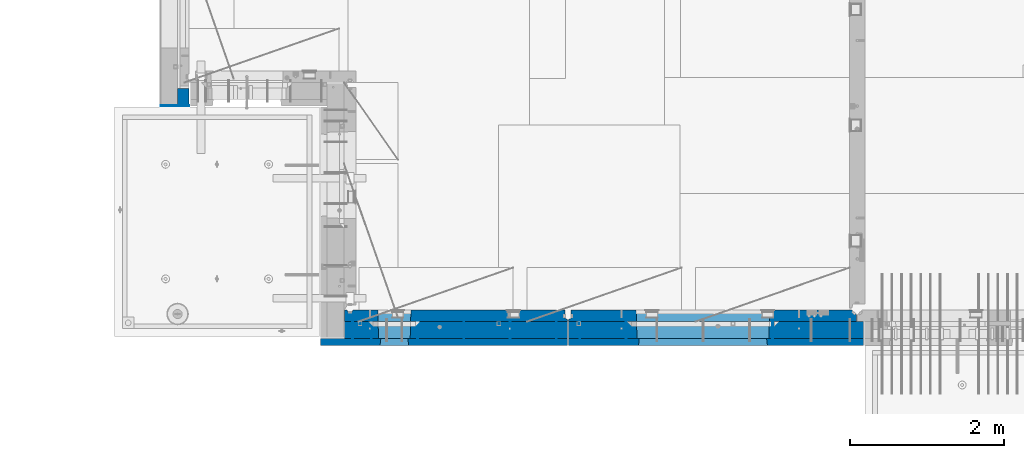
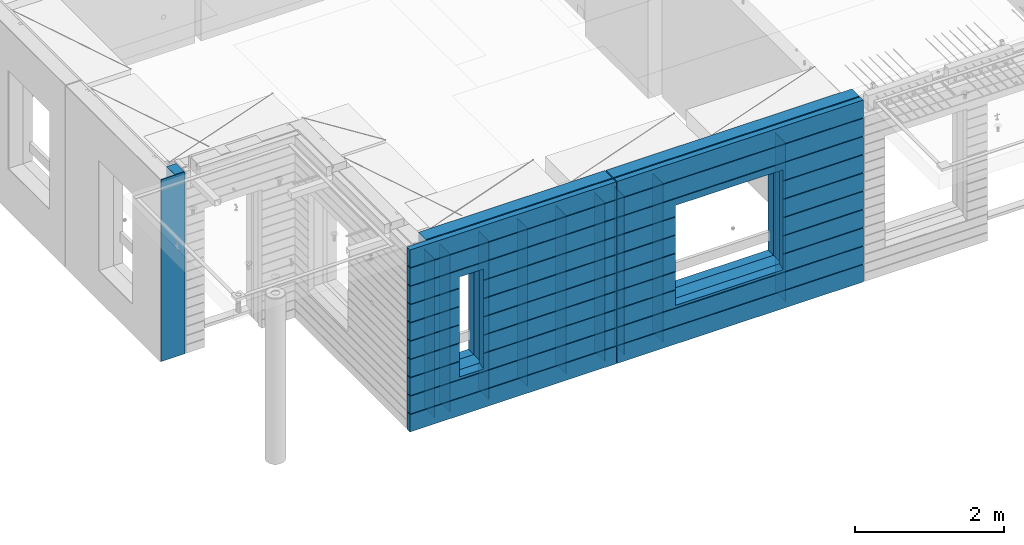
# One storey, part 218 of 341: 17 walls, 3 elements without a shape of their own.
"""IFC2X3 building model written with IfcOpenShell, lengths in millimetres."""

import ifcopenshell
import ifcopenshell.guid

model = None  # the IFC model being written
_history = None  # IfcOwnerHistory: only IFC2X3 demands one
_inside = {}  # id of a spatial element -> (the spatial element, [elements in it])
_under = {}  # id of a project, library or spatial element -> (it, [spatial elements below it])
_declared = {}  # id of a project -> (the project, [libraries it declares])
_typed = {}  # id of a type object -> (the type object, [elements of that type])
_made_of = {}  # id of a material, layer set ... -> (it, [elements and type objects made of it])


def new_model(schema):
    """Start an empty IFC model of exactly this schema.

    Asked for "IFC4X3", IfcOpenShell would pick the latest addendum, in which some entities
    have other attributes; the version numbers below select the first issue.
    IFC2X3 requires an IfcOwnerHistory on every rooted entity: one is made here for all.
    """
    global model, _history
    if schema == "IFC4X3":
        model = ifcopenshell.file(schema_version=(4, 3, 0, 0))
    else:
        model = ifcopenshell.file(schema=schema)
    _inside.clear()
    _under.clear()
    _declared.clear()
    _typed.clear()
    _made_of.clear()
    _history = None
    if model.schema == "IFC2X3":
        org = make("IfcOrganization", Name="unknown")
        user = make(
            "IfcPersonAndOrganization",
            ThePerson=make("IfcPerson", FamilyName="unknown"),
            TheOrganization=org,
        )
        app = make(
            "IfcApplication",
            ApplicationDeveloper=org,
            Version="unknown",
            ApplicationFullName="unknown",
            ApplicationIdentifier="unknown",
        )
        _history = make(
            "IfcOwnerHistory",
            OwningUser=user,
            OwningApplication=app,
            ChangeAction="ADDED",
            CreationDate=0,
        )
    return model


def make(cls, **values):
    """One entity of the class cls with the attributes given. An attribute that is None is left unset."""
    return model.create_entity(
        cls, **{name: value for name, value in values.items() if value is not None}
    )


def rooted(cls, **values):
    """An entity with a GlobalId (a new one), such as an element, a storey or a relation."""
    return make(cls, GlobalId=ifcopenshell.guid.new(), OwnerHistory=_history, **values)


def si_unit(unit_type, name, prefix=None):
    """IfcSIUnit, for example si_unit("LENGTHUNIT", "METRE", prefix="MILLI")."""
    return make("IfcSIUnit", UnitType=unit_type, Prefix=prefix, Name=name)


def assignment(units):
    """IfcUnitAssignment: the units of a project."""
    return None if units is None else make("IfcUnitAssignment", Units=units)


def point(xyz):
    """IfcCartesianPoint."""
    return None if xyz is None else make("IfcCartesianPoint", Coordinates=xyz)


def direction(xyz):
    """IfcDirection."""
    return None if xyz is None else make("IfcDirection", DirectionRatios=xyz)


def frame(location, z_axis=None, x_axis=None):
    """IfcAxis2Placement3D, a coordinate frame: its origin and axes. An axis left out is left unset."""
    return make(
        "IfcAxis2Placement3D",
        Location=point(location),
        Axis=direction(z_axis),
        RefDirection=direction(x_axis),
    )


def origin_with_axes():
    """The frame at (0, 0, 0) with the z axis (0, 0, 1) and the x axis (1, 0, 0) written out."""
    return frame((0.0, 0.0, 0.0), z_axis=(0.0, 0.0, 1.0), x_axis=(1.0, 0.0, 0.0))


def place(relative_to, where):
    """IfcLocalPlacement: puts the frame where relative to a parent placement (None: the world)."""
    return make(
        "IfcLocalPlacement", PlacementRelTo=relative_to, RelativePlacement=where
    )


def context(
    kind, dimensions, precision=None, world=None, true_north=None, identifier=None
):
    """IfcGeometricRepresentationContext, for example the 3D "Model" context."""
    return make(
        "IfcGeometricRepresentationContext",
        ContextIdentifier=identifier,
        ContextType=kind,
        CoordinateSpaceDimension=dimensions,
        Precision=precision,
        WorldCoordinateSystem=world,
        TrueNorth=true_north,
    )


def subcontext(parent, identifier, kind, view, scale=None):
    """IfcGeometricRepresentationSubContext, for example "Body" below "Model"."""
    return make(
        "IfcGeometricRepresentationSubContext",
        ContextIdentifier=identifier,
        ContextType=kind,
        ParentContext=parent,
        TargetScale=scale,
        TargetView=view,
    )


def project(units=None, contexts=None):
    """IfcProject with its units and contexts."""
    return rooted(
        "IfcProject",
        Name="project",
        RepresentationContexts=contexts,
        UnitsInContext=assignment(units),
    )


def spatial(cls, under=None, at=None, **own):
    """A site, building, storey or space (cls), placed at a placement, below another one or the project."""
    s = rooted(cls, ObjectPlacement=at, **own)
    if under is not None:
        _under.setdefault(under.id(), (under, []))[1].append(s)
    return s


def faces_of(points, faces, orient=None, outer=None):
    """IfcFace entities. A face is a list of loops; a loop is a list of indices into points, from 0.

    orient and outer hold one flag for each loop. By default every Orientation is true, the
    first loop of a face is its IfcFaceOuterBound and the others are IfcFaceBound.
    """
    made = []
    for i, loops in enumerate(faces):
        bounds = []
        for j, loop in enumerate(loops):
            is_outer = j == 0 if outer is None else outer[i][j]
            bounds.append(
                make(
                    "IfcFaceOuterBound" if is_outer else "IfcFaceBound",
                    Bound=make("IfcPolyLoop", Polygon=[points[k] for k in loop]),
                    Orientation=True if orient is None else orient[i][j],
                )
            )
        made.append(make("IfcFace", Bounds=bounds))
    return made


def faceted_brep(points, faces, orient=None, outer=None, voids=None):
    """IfcFacetedBrep: a solid bounded by flat faces; with voids (closed shells), ...WithVoids."""
    shared = [point(p) for p in points]
    hull = make("IfcClosedShell", CfsFaces=faces_of(shared, faces, orient, outer))
    if voids is None:
        return make("IfcFacetedBrep", Outer=hull)
    return make(
        "IfcFacetedBrepWithVoids",
        Outer=hull,
        Voids=[
            make(cls, CfsFaces=faces_of(shared, fs, o, b)) for cls, fs, o, b in voids
        ],
    )


def shape(context_of_items, identifier, shape_type, items):
    """IfcShapeRepresentation: the items that make up one representation, for example the "Body"."""
    return make(
        "IfcShapeRepresentation",
        ContextOfItems=context_of_items,
        RepresentationIdentifier=identifier,
        RepresentationType=shape_type,
        Items=items,
    )


def material(Name=None, Category=None):
    """IfcMaterial."""
    return make("IfcMaterial", Name=Name, Category=Category)


def made_of(thing, what):
    """Note that an element or type object is made of a material, layer set ...; save() writes the relation."""
    if what is not None:
        _made_of.setdefault(what.id(), (what, []))[1].append(thing)
    return thing


def type_object(cls, material=None, **own):
    """A type object (cls), such as IfcWallType, which elements share."""
    return made_of(rooted(cls, **own), material)


def element(
    cls,
    number,
    at=None,
    inside=None,
    cuts=None,
    type_object=None,
    material=None,
    context=None,
    identifier="Body",
    shape_type=None,
    held_by="IfcProductDefinitionShape",
    body=None,
    shapes=None,
    **own,
):
    """One element of the class cls, such as IfcWall. Its Tag is "e" and its number.

    at: its placement. inside: the storey or other place that contains it. cuts: it is an
    opening in that element (IfcRelVoidsElement). A single representation is given by context,
    identifier, shape_type and body (its items); several are given by shapes. held_by: the class
    of the entity that holds the representations. save() writes the other relations.
    """
    e = rooted(cls, Tag="e%d" % number, ObjectPlacement=at, **own)
    if body is not None:
        shapes = [shape(context, identifier, shape_type, body)]
    if shapes is not None:
        e.Representation = make(held_by, Representations=shapes)
    if inside is not None:
        _inside.setdefault(inside.id(), (inside, []))[1].append(e)
    if cuts is not None:
        rooted(
            "IfcRelVoidsElement", RelatingBuildingElement=cuts, RelatedOpeningElement=e
        )
    if type_object is not None:
        _typed.setdefault(type_object.id(), (type_object, []))[1].append(e)
    return made_of(e, material)


def aggregate(whole, parts):
    """IfcRelAggregates: a whole, such as a stair, and the parts it consists of."""
    return rooted("IfcRelAggregates", RelatingObject=whole, RelatedObjects=parts)


def save(model, path):
    """Write the relations noted so far, then the file.

    IfcRelAggregates (storeys below a building ...), IfcRelContainedInSpatialStructure (elements
    in a storey), IfcRelDefinesByType, IfcRelAssociatesMaterial and IfcRelDeclares: one each for
    every whole, place, type object, material and project.
    """
    for whole, parts in _under.values():
        aggregate(whole, parts)
    for where, things in _inside.values():
        rooted(
            "IfcRelContainedInSpatialStructure",
            RelatedElements=things,
            RelatingStructure=where,
        )
    for kind, things in _typed.values():
        rooted("IfcRelDefinesByType", RelatedObjects=things, RelatingType=kind)
    for what, things in _made_of.values():
        rooted("IfcRelAssociatesMaterial", RelatedObjects=things, RelatingMaterial=what)
    for by, libraries in _declared.values():
        rooted("IfcRelDeclares", RelatingContext=by, RelatedDefinitions=libraries)
    model.write(path)


model = new_model("IFC2X3")

# Units and contexts
model_context = context("Model", 3, precision=1e-05, world=origin_with_axes())
body_context = subcontext(model_context, "Body", "Model", "MODEL_VIEW")
ifc_project = project(units=[si_unit("LENGTHUNIT", "METRE", prefix="MILLI"), si_unit("AREAUNIT", "SQUARE_METRE"), si_unit("VOLUMEUNIT", "CUBIC_METRE"), si_unit("MASSUNIT", "GRAM", prefix="KILO"), si_unit("TIMEUNIT", "SECOND"), si_unit("PLANEANGLEUNIT", "RADIAN"), si_unit("SOLIDANGLEUNIT", "STERADIAN"), si_unit("THERMODYNAMICTEMPERATUREUNIT", "DEGREE_CELSIUS"), si_unit("LUMINOUSINTENSITYUNIT", "LUMEN")], contexts=[model_context])

# Site, building, storey
site_placement = place(None, origin_with_axes())
site = spatial("IfcSite", under=ifc_project, at=site_placement, CompositionType="ELEMENT")
building_placement = place(site_placement, origin_with_axes())
building = spatial("IfcBuilding", under=site, at=building_placement, CompositionType="ELEMENT")
storey_placement = place(building_placement, origin_with_axes())
storey = spatial("IfcBuildingStorey", under=building, at=storey_placement, Name="5", CompositionType="ELEMENT", Elevation=0.0)

# Assembly, walls
assembly_1_placement = place(storey_placement, origin_with_axes())
assembly_1 = element("IfcElementAssembly", 1, at=assembly_1_placement, inside=storey, AssemblyPlace="NOTDEFINED", PredefinedType="REINFORCEMENT_UNIT")
ifc_material_1 = material(Name="Undefined")
wall_type_1 = type_object("IfcWallType", PredefinedType="NOTDEFINED")
wall_1_placement = place(assembly_1_placement, frame((10122.5, 7880.0, 95115.0), z_axis=(0.0, 0.0, 1.0), x_axis=(0.0, -1.0, 0.0)))
wall_1 = element("IfcWall", 2, at=wall_1_placement, type_object=wall_type_1, material=ifc_material_1, Name="(PD)", context=body_context, shape_type="Brep", body=[
    faceted_brep([(0.0, 5.0, -1300.0), (0.0, 5.0, 1300.0), (280.0, 5.0, 1300.0), (280.0, 5.0, -1300.0), (0.0, -5.0, 1300.0), (280.0, -5.0, 1300.0), (0.0, -5.0, -1300.0), (280.0, -5.0, -1300.0)], [[[0, 1, 2, 3]], [[1, 4, 5, 2]], [[4, 6, 7, 5]], [[6, 0, 3, 7]], [[5, 7, 3, 2]], [[6, 4, 1, 0]]]),
])
wall_2_placement = place(assembly_1_placement, frame((10362.5, 7880.0, 95115.0), z_axis=(0.0, 0.0, 1.0), x_axis=(0.0, -1.0, 0.0)))
wall_2 = element("IfcWall", 3, at=wall_2_placement, type_object=wall_type_1, material=ifc_material_1, Name="(PD)", context=body_context, shape_type="Brep", body=[
    faceted_brep([(0.0, 5.0, -1300.0), (0.0, 5.0, 1300.0), (280.0, 5.0, 1300.0), (280.0, 5.0, -1300.0), (0.0, -5.0, 1300.0), (280.0, -5.0, 1300.0), (0.0, -5.0, -1300.0), (280.0, -5.0, -1300.0)], [[[0, 1, 2, 3]], [[1, 4, 5, 2]], [[4, 6, 7, 5]], [[6, 0, 3, 7]], [[5, 7, 3, 2]], [[6, 4, 1, 0]]]),
])
wall_3_placement = place(assembly_1_placement, frame((10962.5, 7880.0, 95115.0), z_axis=(0.0, 0.0, 1.0), x_axis=(0.0, -1.0, 0.0)))
wall_3 = element("IfcWall", 4, at=wall_3_placement, type_object=wall_type_1, material=ifc_material_1, Name="(PD)", context=body_context, shape_type="Brep", body=[
    faceted_brep([(0.0, 5.0, -1300.0), (0.0, 5.0, 1300.0), (280.0, 5.0, 1300.0), (280.0, 5.0, -1300.0), (0.0, -5.0, 1300.0), (280.0, -5.0, 1300.0), (0.0, -5.0, -1300.0), (280.0, -5.0, -1300.0)], [[[0, 1, 2, 3]], [[1, 4, 5, 2]], [[4, 6, 7, 5]], [[6, 0, 3, 7]], [[5, 7, 3, 2]], [[6, 4, 1, 0]]]),
])
wall_4_placement = place(assembly_1_placement, frame((11562.5, 7880.0, 95115.0), z_axis=(0.0, 0.0, 1.0), x_axis=(0.0, -1.0, 0.0)))
wall_4 = element("IfcWall", 5, at=wall_4_placement, type_object=wall_type_1, material=ifc_material_1, Name="(PD)", context=body_context, shape_type="Brep", body=[
    faceted_brep([(0.0, 5.0, -1300.0), (0.0, 5.0, 1300.0), (280.0, 5.0, 1300.0), (280.0, 5.0, -1300.0), (0.0, -5.0, 1300.0), (280.0, -5.0, 1300.0), (0.0, -5.0, -1300.0), (280.0, -5.0, -1300.0)], [[[0, 1, 2, 3]], [[1, 4, 5, 2]], [[4, 6, 7, 5]], [[6, 0, 3, 7]], [[5, 7, 3, 2]], [[6, 4, 1, 0]]]),
])
wall_5_placement = place(assembly_1_placement, frame((12162.5, 7880.0, 95115.0), z_axis=(0.0, 0.0, 1.0), x_axis=(0.0, -1.0, 0.0)))
wall_5 = element("IfcWall", 6, at=wall_5_placement, type_object=wall_type_1, material=ifc_material_1, Name="(PD)", context=body_context, shape_type="Brep", body=[
    faceted_brep([(0.0, 5.0, -1300.0), (0.0, 5.0, 1300.0), (280.0, 5.0, 1300.0), (280.0, 5.0, -1300.0), (0.0, -5.0, 1300.0), (280.0, -5.0, 1300.0), (0.0, -5.0, -1300.0), (280.0, -5.0, -1300.0)], [[[0, 1, 2, 3]], [[1, 4, 5, 2]], [[4, 6, 7, 5]], [[6, 0, 3, 7]], [[5, 7, 3, 2]], [[6, 4, 1, 0]]]),
])
wall_6_placement = place(assembly_1_placement, frame((12762.5, 7880.0, 95115.0), z_axis=(0.0, 0.0, 1.0), x_axis=(0.0, -1.0, 0.0)))
wall_6 = element("IfcWall", 7, at=wall_6_placement, type_object=wall_type_1, material=ifc_material_1, Name="(PD)", context=body_context, shape_type="Brep", body=[
    faceted_brep([(0.0, 5.0, -1300.0), (0.0, 5.0, 1300.0), (280.0, 5.0, 1300.0), (280.0, 5.0, -1300.0), (0.0, -5.0, 1300.0), (280.0, -5.0, 1300.0), (0.0, -5.0, -1300.0), (280.0, -5.0, -1300.0)], [[[0, 1, 2, 3]], [[1, 4, 5, 2]], [[4, 6, 7, 5]], [[6, 0, 3, 7]], [[5, 7, 3, 2]], [[6, 4, 1, 0]]]),
])

assembly_2_placement = place(storey_placement, origin_with_axes())
assembly_2 = element("IfcElementAssembly", 8, at=assembly_2_placement, inside=storey, AssemblyPlace="NOTDEFINED", PredefinedType="REINFORCEMENT_UNIT")
wall_7_placement = place(assembly_2_placement, frame((13665.0, 7880.0, 95115.0), z_axis=(0.0, 0.0, 1.0), x_axis=(0.0, -1.0, 0.0)))
wall_7 = element("IfcWall", 9, at=wall_7_placement, type_object=wall_type_1, material=ifc_material_1, Name="(PD)", context=body_context, shape_type="Brep", body=[
    faceted_brep([(0.0, 5.0, -1300.0), (0.0, 5.0, 1300.0), (280.0, 5.0, 1300.0), (280.0, 5.0, -1300.0), (0.0, -5.0, 1300.0), (280.0, -5.0, 1300.0), (0.0, -5.0, -1300.0), (280.0, -5.0, -1300.0)], [[[0, 1, 2, 3]], [[1, 4, 5, 2]], [[4, 6, 7, 5]], [[6, 0, 3, 7]], [[5, 7, 3, 2]], [[6, 4, 1, 0]]]),
])
wall_8_placement = place(assembly_2_placement, frame((13065.0, 7880.0, 95115.0), z_axis=(0.0, 0.0, 1.0), x_axis=(0.0, -1.0, 0.0)))
wall_8 = element("IfcWall", 10, at=wall_8_placement, type_object=wall_type_1, material=ifc_material_1, Name="(PD)", context=body_context, shape_type="Brep", body=[
    faceted_brep([(0.0, 5.0, -1300.0), (0.0, 5.0, 1300.0), (280.0, 5.0, 1300.0), (280.0, 5.0, -1300.0), (0.0, -5.0, 1300.0), (280.0, -5.0, 1300.0), (0.0, -5.0, -1300.0), (280.0, -5.0, -1300.0)], [[[0, 1, 2, 3]], [[1, 4, 5, 2]], [[4, 6, 7, 5]], [[6, 0, 3, 7]], [[5, 7, 3, 2]], [[6, 4, 1, 0]]]),
])
wall_9_placement = place(assembly_2_placement, frame((15565.0, 7880.0, 95115.0), z_axis=(0.0, 0.0, 1.0), x_axis=(0.0, -1.0, 0.0)))
wall_9 = element("IfcWall", 11, at=wall_9_placement, type_object=wall_type_1, material=ifc_material_1, Name="(PD)", context=body_context, shape_type="Brep", body=[
    faceted_brep([(0.0, 5.0, -1300.0), (0.0, 5.0, 1300.0), (280.0, 5.0, 1300.0), (280.0, 5.0, -1300.0), (0.0, -5.0, 1300.0), (280.0, -5.0, 1300.0), (0.0, -5.0, -1300.0), (280.0, -5.0, -1300.0)], [[[0, 1, 2, 3]], [[1, 4, 5, 2]], [[4, 6, 7, 5]], [[6, 0, 3, 7]], [[5, 7, 3, 2]], [[6, 4, 1, 0]]]),
])

# Assembly, wall
assembly_3_placement = place(storey_placement, origin_with_axes())
assembly_3 = element("IfcElementAssembly", 12, at=assembly_3_placement, inside=storey, AssemblyPlace="NOTDEFINED", PredefinedType="REINFORCEMENT_UNIT")
ifc_material_2 = material()
wall_type_2 = type_object("IfcWallType", PredefinedType="NOTDEFINED")
wall_10_placement = place(assembly_3_placement, frame((8000.00051558999, 10765.0000158944, 95247.5), z_axis=(0.0, 0.0, 1.0), x_axis=(-0.999999999997437, -2.26400000064461e-06, 0.0)))
wall_10 = element("IfcWall", 13, at=wall_10_placement, type_object=wall_type_2, material=ifc_material_2, context=body_context, shape_type="Brep", body=[
    faceted_brep([(0.0, 110.0, -1492.5), (0.0, 110.0, 1492.5), (150.000694320282, 109.999999999998, 1492.5), (150.000694320282, 109.999999999998, -1492.5), (0.0, -110.0, 1492.5), (150.000694320282, -110.000000000004, 1492.5), (0.0, -110.0, -1492.5), (150.000694320282, -110.000000000004, -1492.5)], [[[0, 1, 2, 3]], [[1, 4, 5, 2]], [[4, 6, 7, 5]], [[6, 0, 3, 7]], [[5, 7, 3, 2]], [[6, 4, 1, 0]]]),
])

# Wall
ifc_material_3 = material(Name="COS5gt")
wall_11_placement = place(assembly_1_placement, frame((12912.5, 7740.0, 95247.5), z_axis=(0.0, 0.0, 1.0), x_axis=(-1.0, 3.00000001838171e-08, 0.0)))
wall_11 = element("IfcWall", 14, at=wall_11_placement, type_object=wall_type_2, material=ifc_material_3, context=body_context, shape_type="Brep", body=[
    faceted_brep([(7.5, 90.0, 1442.5), (2897.5, 90.0, 1442.5), (2897.5, 110.0, 1442.5), (7.5, 110.0, 1442.5), (7.5, 90.0, 1492.5), (2897.5, 90.0, 1492.5), (7.5, -110.0, 1492.5), (2897.5, -110.0, 1492.5), (2897.5, -110.0, -1492.5), (2897.5, 90.0, -1492.5), (2897.5, 90.0, -1442.5), (2897.5, 110.0, -1442.5), (7.5, 110.0, -1442.5), (7.5, 90.0, -1442.5), (2047.50059444406, 110.0, -807.5), (2077.50059444406, 110.0, -807.5), (2427.50059444406, 110.0, -807.5), (2457.50059444406, 110.0, -807.5), (2457.50059444406, 110.0, -802.5), (2457.50059444406, 110.0, 807.5), (2047.50059444406, 110.0, 807.5), (2047.50059444406, 110.0, -802.5), (2041.55464849811, -110.0, -813.445945945947), (2041.55464849811, -110.0, 813.445945945947), (2463.44654039001, -110.0, -813.445945945947), (2463.44654039001, -110.0, 813.445945945947), (7.5, -110.0, -1492.5), (7.5, 90.0, -1492.5)], [[[0, 1, 2, 3]], [[4, 5, 1, 0]], [[6, 7, 5, 4]], [[2, 1, 5, 7, 8, 9, 10, 11]], [[12, 11, 10, 13]], [[3, 2, 11, 12], [14, 15, 16, 17, 18, 19, 20, 21]], [[22, 14, 21, 20, 23]], [[24, 17, 16, 15, 14, 22]], [[18, 17, 24, 25, 19]], [[23, 20, 19, 25]], [[6, 26, 8, 7], [24, 22, 23, 25]], [[8, 26, 27, 9]], [[13, 10, 9, 27]], [[26, 6, 4, 0, 3, 12, 13, 27]]]),
])

wall_12_placement = place(assembly_2_placement, frame((16740.0, 7740.0, 95247.5), z_axis=(0.0, 0.0, 1.0), x_axis=(-1.0, 3.00000001838171e-08, 0.0)))
wall_12 = element("IfcWall", 15, at=wall_12_placement, type_object=wall_type_2, material=ifc_material_3, context=body_context, shape_type="Brep", body=[
    faceted_brep([(0.0, 90.0, 1442.5), (3820.0, 90.0, 1442.5), (3820.0, 110.0, 1442.5), (0.0, 110.0, 1442.5), (0.0, 90.0, 1492.5), (3820.0, 90.0, 1492.5), (0.0, -110.0, 1492.5), (3820.0, -110.0, 1492.5), (3820.0, -110.0, -1492.5), (3820.0, 90.0, -1492.5), (3820.0, 90.0, -1442.5), (3820.0, 110.0, -1442.5), (0.0, 110.0, -1442.5), (0.0, 90.0, -1442.5), (1224.99975425761, 110.0, -807.5), (1254.99975425761, 110.0, -807.5), (2904.99975425761, 110.0, -807.5), (2934.99975425761, 110.0, -807.5), (2934.99975425761, 110.0, -802.5), (2934.99975425761, 110.0, 807.5), (1224.99975425761, 110.0, 807.5), (1224.99975425761, 110.0, -802.5), (1219.05380831167, -110.0, -813.445945945947), (1219.05380831167, -110.0, 813.445945945947), (2940.94570020356, -110.0, -813.445945945947), (2940.94570020356, -110.0, 813.445945945947), (0.0, -110.0, -1492.5), (0.0, 90.0, -1492.5)], [[[0, 1, 2, 3]], [[4, 5, 1, 0]], [[6, 7, 5, 4]], [[2, 1, 5, 7, 8, 9, 10, 11]], [[12, 11, 10, 13]], [[3, 2, 11, 12], [14, 15, 16, 17, 18, 19, 20, 21]], [[22, 14, 21, 20, 23]], [[24, 17, 16, 15, 14, 22]], [[18, 17, 24, 25, 19]], [[23, 20, 19, 25]], [[6, 26, 8, 7], [24, 22, 23, 25]], [[8, 26, 27, 9]], [[13, 10, 9, 27]], [[27, 26, 6, 4, 0, 3, 12, 13]]]),
])

ifc_material_4 = material(Name="CONCRETE/C30/37")
wall_type_3 = type_object("IfcWallType", PredefinedType="NOTDEFINED")
wall_13_placement = place(assembly_1_placement, frame((12912.5, 7587.5, 95247.5), z_axis=(0.0, 0.0, 1.0), x_axis=(-1.0, 3.00000001838171e-08, 0.0)))
wall_13 = element("IfcWall", 16, at=wall_13_placement, type_object=wall_type_3, material=ifc_material_4, context=body_context, shape_type="Brep", body=[
    faceted_brep([(3207.5, -42.5, 1193.0000011433), (3207.5, 42.5, 1192.99999994476), (3197.49999925687, 32.4999992501671, 1194.99999999921), (3197.49999396174, -42.5, 1195.00000105656), (3197.49999368253, -42.5, 1205.00000145777), (3197.49999897767, 32.4999991121604, 1205.00000040043), (3207.5, 42.5, 1206.99999988925), (3207.5, -42.5, 1207.0000010878), (7.4999999999709, -42.5, -1492.5), (7.4999999999709, 42.5, -1492.5), (3207.5, 42.5, -1492.5), (3207.5, -42.5, -1492.5), (7.4999999999709, 42.5, -1207.00000005524), (3207.5, 42.5, -1207.00000005524), (3207.5, -42.5, -1206.9999988567), (3197.49999925687, 32.4999992501671, -1205.00000000079), (3197.49999396174, -42.5, -1204.99999894344), (7.4999999999709, 32.4999992501671, -1205.00000000079), (7.4999999999709, 32.4999991121604, -1194.99999959957), (3197.49999897767, 32.4999991121604, -1194.99999959957), (3197.49999368253, -42.5, -1194.99999854223), (3207.5, -42.5, -1192.9999989122), (3207.5, 42.5, -1193.00000011075), (3207.5, 42.5, -907.000000055239), (3207.5, -42.5, -906.9999988567), (7.4999999999709, 42.5, -1193.00000011075), (7.4999999999709, 42.5, -907.000000055239), (7.4999999999709, 32.4999992501671, -905.000000000786), (3197.49999925687, 32.4999992501671, -905.000000000786), (3197.49999396174, -42.5, -904.999998943444), (3197.49999897767, 32.4999991121604, -894.999999599575), (3197.49999368253, -42.5, -894.999998542233), (7.4999999999709, 32.4999991121604, -894.999999599575), (7.4999999999709, 42.5, -893.000000110755), (3207.5, 42.5, -893.000000110755), (3207.5, -42.5, -892.999998912201), (3207.5, 42.5, -607.000000055239), (3207.5, -42.5, -606.9999988567), (3197.49999925687, 32.4999992501671, -605.000000000786), (3197.49999396174, -42.5, -604.999998943444), (2437.50059444406, 42.5, -607.000000055239), (2436.32412376761, 32.4999992501671, -605.000000000786), (2436.32412375137, 32.4999991121604, -594.999999599575), (3197.49999897767, 32.4999991121604, -594.999999599575), (3197.49999368253, -42.5, -594.999998542233), (3207.5, 42.5, -593.000000110755), (3207.5, -42.5, -592.999998912201), (2437.50059444406, 42.5, -593.000000110755), (3207.5, 42.5, -307.000000055239), (2437.50059444406, 42.5, -307.000000055239), (3207.5, -42.5, -306.9999988567), (3197.49999925687, 32.4999992501671, -305.000000000786), (3197.49999396174, -42.5, -304.999998943444), (2436.32412376761, 32.4999992501671, -305.000000000786), (2436.32412375137, 32.4999991121604, -294.999999599575), (3197.49999897767, 32.4999991121604, -294.999999599575), (3197.49999368253, -42.5, -294.999998542233), (3207.5, 42.5, -293.000000110755), (3207.5, -42.5, -292.999998912201), (2437.50059444406, 42.5, -293.000000110755), (3207.5, 42.5, -7.00000005523907), (2437.50059444406, 42.5, -7.00000005523907), (3207.5, -42.5, -6.99999885669968), (3197.49999925687, 32.4999992501671, -5.0000000007858), (3197.49999396174, -42.5, -4.99999894344364), (2436.32412376761, 32.4999992501671, -5.0000000007858), (2436.32412375137, 32.4999991121604, 5.00000040042505), (3197.49999897767, 32.4999991121604, 5.00000040042505), (3197.49999368253, -42.5, 5.00000145776721), (3207.5, 42.5, 6.99999988924537), (3207.5, -42.5, 7.00000108779932), (2437.50059444406, 42.5, 6.99999988924537), (3207.5, 42.5, 292.999999944761), (2437.50059444406, 42.5, 292.999999944761), (3207.5, -42.5, 293.0000011433), (3197.49999925687, 32.4999992501671, 294.999999999214), (3197.49999396174, -42.5, 295.000001056556), (2436.32412376761, 32.4999992501671, 294.999999999214), (2436.32412375137, 32.4999991121604, 305.000000400425), (3197.49999897767, 32.4999991121604, 305.000000400425), (3197.49999368253, -42.5, 305.000001457767), (3207.5, -42.5, 307.000001087799), (3207.5, 42.5, 306.999999889245), (3207.5, 42.5, 592.999999944761), (3207.5, -42.5, 593.0000011433), (2437.50059444406, 42.5, 306.999999889245), (2437.50059444406, 42.5, 592.999999944761), (2436.32412376761, 32.4999992501671, 594.999999999214), (3197.49999925687, 32.4999992501671, 594.999999999214), (3197.49999396174, -42.5, 595.000001056556), (3197.49999897767, 32.4999991121604, 605.000000400425), (3197.49999368253, -42.5, 605.000001457767), (2436.32412375137, 32.4999991121604, 605.000000400425), (2437.50059444406, 42.5, 606.999999889245), (3207.5, 42.5, 606.999999889245), (3207.5, -42.5, 607.000001087799), (3207.5, 42.5, 892.999999944761), (3207.5, -42.5, 893.0000011433), (3197.49999925687, 32.4999992501671, 894.999999999214), (3197.49999396174, -42.5, 895.000001056556), (7.4999999999709, 42.5, 892.999999944761), (7.49999999998181, 32.4999992501671, 894.999999999214), (7.49999999998181, 32.4999991121604, 905.000000400425), (3197.49999897767, 32.4999991121604, 905.000000400425), (3197.49999368253, -42.5, 905.000001457767), (3207.5, -42.5, 907.000001087799), (3207.5, 42.5, 906.999999889245), (7.4999999999709, 42.5, 906.999999889245), (7.4999999999709, 42.5, 1192.99999994476), (7.49999999998363, 32.4999992501671, 1194.99999999921), (7.4999999999709, 42.5, 1492.5), (7.4999999999709, -42.5, 1492.5), (3207.5, -42.5, 1492.5), (3207.5, 42.5, 1492.5), (7.4999999999709, 42.5, 1206.99999988925), (7.49999999998363, 32.4999991121604, 1205.00000040043), (7.4999999999709, 42.5, 606.999999889245), (7.49999999997999, 32.4999991121604, 605.000000400425), (7.49999999997999, 32.4999992501671, 594.999999999214), (7.4999999999709, 42.5, 592.999999944761), (7.4999999999709, 42.5, 306.999999889245), (7.49999999997453, 32.4999991121604, 305.000000400425), (7.49999999997453, 32.4999992501671, 294.999999999214), (7.4999999999709, 42.5, 292.999999944761), (7.4999999999709, 42.5, 6.99999988924537), (7.4999999999709, 32.4999991121604, 5.00000040042505), (7.4999999999709, 32.4999992501671, -5.0000000007858), (7.4999999999709, 42.5, -7.00000005523907), (7.4999999999709, 42.5, -293.000000110755), (7.4999999999709, 32.4999991121604, -294.999999599575), (7.4999999999709, 32.4999992501671, -305.000000000786), (7.4999999999709, 42.5, -307.000000055239), (7.4999999999709, 42.5, -593.000000110755), (7.49999999996908, 32.4999991121604, -594.999999599575), (7.49999999996908, 32.4999992501671, -605.000000000786), (7.4999999999709, 42.5, -607.000000055239), (2068.67706513675, 32.4999991121604, 605.000000400425), (2068.67706512051, 32.4999992501671, 594.999999999214), (2067.50059444406, 42.5, 592.999999944761), (2067.50059444406, 42.5, 306.999999889245), (2068.67706513675, 32.4999991121604, 305.000000400425), (2068.67706512051, 32.4999992501671, 294.999999999214), (2067.50059444406, 42.5, 292.999999944761), (2067.50059444406, 42.5, 6.99999988924537), (2068.67706513675, 32.4999991121604, 5.00000040042505), (2068.67706512051, 32.4999992501671, -5.0000000007858), (2067.50059444406, 42.5, -7.00000005523907), (2067.50059444406, 42.5, -293.000000110755), (2068.67706513675, 32.4999991121604, -294.999999599575), (2068.67706512051, 32.4999992501671, -305.000000000786), (2067.50059444406, 42.5, -307.000000055239), (2067.50059444406, 42.5, -593.000000110755), (2068.67706513675, 32.4999991121604, -594.999999599575), (2068.67706512051, 32.4999992501671, -605.000000000786), (2067.50059444406, 42.5, -607.000000055239), (2437.50059444406, 42.5, -857.5), (2067.50059444406, 42.5, -857.5), (2077.50059444406, -42.5, -807.5), (2427.50059444406, -42.5, -807.5), (2427.50059444406, -42.5, 782.5), (2427.50059444406, -42.5, 787.5), (2437.50059444406, 42.5, 782.5), (2427.50059444406, 42.5, 782.5), (2077.50059444406, 42.5, 782.5), (2067.50059444406, 42.5, 782.5), (2067.50059444406, 42.5, 606.999999889245), (2077.50059444406, -42.5, 787.5), (2077.50059444406, -42.5, 782.5)], [[[0, 1, 2, 3]], [[4, 5, 6, 7]], [[3, 2, 5, 4]], [[8, 9, 10, 11]], [[10, 9, 12, 13]], [[11, 10, 13, 14]], [[14, 13, 15, 16]], [[12, 17, 15, 13]], [[17, 18, 19, 15]], [[16, 15, 19, 20]], [[21, 22, 23, 24]], [[20, 19, 22, 21]], [[18, 25, 22, 19]], [[22, 25, 26, 23]], [[26, 27, 28, 23]], [[24, 23, 28, 29]], [[29, 28, 30, 31]], [[27, 32, 30, 28]], [[32, 33, 34, 30]], [[31, 30, 34, 35]], [[35, 34, 36, 37]], [[37, 36, 38, 39]], [[40, 41, 38, 36]], [[41, 42, 43, 38]], [[39, 38, 43, 44]], [[44, 43, 45, 46]], [[42, 47, 45, 43]], [[48, 45, 47, 49]], [[46, 45, 48, 50]], [[50, 48, 51, 52]], [[49, 53, 51, 48]], [[53, 54, 55, 51]], [[52, 51, 55, 56]], [[56, 55, 57, 58]], [[54, 59, 57, 55]], [[60, 57, 59, 61]], [[58, 57, 60, 62]], [[62, 60, 63, 64]], [[61, 65, 63, 60]], [[65, 66, 67, 63]], [[64, 63, 67, 68]], [[68, 67, 69, 70]], [[66, 71, 69, 67]], [[72, 69, 71, 73]], [[70, 69, 72, 74]], [[74, 72, 75, 76]], [[73, 77, 75, 72]], [[77, 78, 79, 75]], [[76, 75, 79, 80]], [[81, 82, 83, 84]], [[80, 79, 82, 81]], [[78, 85, 82, 79]], [[83, 82, 85, 86]], [[86, 87, 88, 83]], [[84, 83, 88, 89]], [[89, 88, 90, 91]], [[87, 92, 90, 88]], [[92, 93, 94, 90]], [[91, 90, 94, 95]], [[95, 94, 96, 97]], [[97, 96, 98, 99]], [[100, 101, 98, 96]], [[101, 102, 103, 98]], [[99, 98, 103, 104]], [[105, 106, 1, 0]], [[104, 103, 106, 105]], [[102, 107, 106, 103]], [[106, 107, 108, 1]], [[108, 109, 2, 1]], [[110, 111, 112, 113]], [[113, 112, 7, 6]], [[110, 113, 6, 114]], [[115, 114, 6, 5]], [[109, 115, 5, 2]], [[108, 107, 102, 101, 100, 116, 117, 118, 119, 120, 121, 122, 123, 124, 125, 126, 127, 128, 129, 130, 131, 132, 133, 134, 135, 33, 32, 27, 26, 25, 18, 17, 12, 9, 8, 111, 110, 114, 115, 109]], [[118, 117, 136, 137]], [[119, 118, 137, 138]], [[120, 119, 138, 139]], [[121, 120, 139, 140]], [[122, 121, 140, 141]], [[123, 122, 141, 142]], [[124, 123, 142, 143]], [[125, 124, 143, 144]], [[126, 125, 144, 145]], [[127, 126, 145, 146]], [[128, 127, 146, 147]], [[129, 128, 147, 148]], [[130, 129, 148, 149]], [[131, 130, 149, 150]], [[132, 131, 150, 151]], [[133, 132, 151, 152]], [[134, 133, 152, 153]], [[135, 134, 153, 154]], [[155, 40, 36, 34, 33, 135, 154, 156]], [[156, 157, 158, 155]], [[159, 160, 161, 93, 92, 87, 86, 85, 78, 77, 73, 71, 66, 65, 61, 59, 54, 53, 49, 47, 42, 41, 40, 155, 158]], [[116, 100, 96, 94, 93, 161, 162, 163, 164, 165]], [[117, 116, 165, 136]], [[164, 166, 167, 157, 156, 154, 153, 152, 151, 150, 149, 148, 147, 146, 145, 144, 143, 142, 141, 140, 139, 138, 137, 136, 165]], [[163, 162, 161, 160, 166, 164]], [[112, 111, 8, 11, 14, 16, 20, 21, 24, 29, 31, 35, 37, 39, 44, 46, 50, 52, 56, 58, 62, 64, 68, 70, 74, 76, 80, 81, 84, 89, 91, 95, 97, 99, 104, 105, 0, 3, 4, 7], [159, 158, 157, 167, 166, 160]]]),
])

wall_14_placement = place(assembly_2_placement, frame((16740.0, 7587.5, 95247.5), z_axis=(0.0, 0.0, 1.0), x_axis=(-1.0, 3.00000001838171e-08, 0.0)))
wall_14 = element("IfcWall", 17, at=wall_14_placement, type_object=wall_type_3, material=ifc_material_4, context=body_context, shape_type="Brep", body=[
    faceted_brep([(3820.00000000003, 42.5, 606.999999889245), (3820.00000000002, 32.4999991121731, 605.00000040044), (2913.82328356493, 32.4999991121731, 605.00000040044), (2914.99975425761, 42.5, 606.999999889245), (3820.00000000002, 32.4999992501716, 594.999999999243), (2913.82328358116, 32.4999992501716, 594.999999999243), (3820.00000000003, 42.5, 592.999999944761), (2914.99975425761, 42.5, 592.999999944761), (3820.00000000003, 42.5, 306.999999889245), (2914.99975425761, 42.5, 306.999999889245), (3820.00000000002, 32.4999991121731, 305.00000040044), (2913.82328356493, 32.4999991121731, 305.00000040044), (3820.00000000002, 32.4999992501716, 294.999999999243), (2913.82328358116, 32.4999992501716, 294.999999999243), (3820.00000000003, 42.5, 292.999999944761), (2914.99975425761, 42.5, 292.999999944761), (3820.00000000003, 42.5, 6.99999988924537), (2914.99975425761, 42.5, 6.99999988924537), (3820.00000000003, 32.4999991121731, 5.0000004004396), (2913.82328356493, 32.4999991121731, 5.0000004004396), (3820.00000000003, 32.4999992501716, -5.0000000007567), (2913.82328358116, 32.4999992501716, -5.0000000007567), (3820.00000000003, 42.5, -7.00000005523907), (2914.99975425761, 42.5, -7.00000005523907), (3820.00000000003, 42.5, -293.000000110755), (2914.99975425761, 42.5, -293.000000110755), (3820.00000000003, 32.4999991121731, -294.99999959956), (2913.82328356493, 32.4999991121731, -294.99999959956), (3820.00000000003, 32.4999992501716, -305.000000000757), (2913.82328358116, 32.4999992501716, -305.000000000757), (3820.00000000003, 42.5, -307.000000055239), (2914.99975425761, 42.5, -307.000000055239), (3820.00000000003, 42.5, -593.000000110755), (2914.99975425761, 42.5, -593.000000110755), (3820.00000000003, 32.4999991121731, -594.99999959956), (2913.82328356493, 32.4999991121731, -594.99999959956), (3820.00000000003, 32.4999992501716, -605.000000000757), (2913.82328358116, 32.4999992501716, -605.000000000757), (3820.00000000003, 42.5, -607.000000055239), (2914.99975425761, 42.5, -607.000000055239), (0.0, -42.5, -1492.5), (0.0, 42.5, -1492.5), (3820.00000000003, 42.5, -1492.5), (3820.00000000003, -42.5, -1492.5), (0.0, 42.5, -1207.00000005524), (3820.00000000003, 42.5, -1207.00000005524), (0.0, 32.4999992507037, -1205.00000000074), (3820.00000000003, 32.4999992501716, -1205.00000000076), (0.0, 32.4999991127006, -1194.99999959956), (3820.00000000003, 32.4999991121731, -1194.99999959956), (0.0, 42.5, -1193.00000011075), (3820.00000000003, 42.5, -1193.00000011075), (0.0, 42.5, -907.000000055239), (3820.00000000003, 42.5, -907.000000055239), (0.0, 32.4999992507037, -905.000000000742), (3820.00000000003, 32.4999992501716, -905.000000000757), (0.0, 32.4999991127006, -894.99999959956), (3820.00000000003, 32.4999991121731, -894.99999959956), (0.0, 42.5, -893.000000110755), (3820.00000000003, 42.5, -893.000000110755), (3.63797880709171e-12, 32.4999992507037, 594.999999999258), (3.63797880709171e-12, 32.4999991127006, 605.00000040044), (1246.1762249503, 32.4999991121731, 605.00000040044), (1246.17622493406, 32.4999992501716, 594.999999999243), (0.0, 42.5, 592.999999944761), (1244.99975425761, 42.5, 592.999999944761), (0.0, 42.5, 306.999999889245), (1244.99975425761, 42.5, 306.999999889245), (-3.63797880709171e-12, 32.4999991127006, 305.00000040044), (1246.1762249503, 32.4999991121731, 305.00000040044), (-3.63797880709171e-12, 32.4999992507037, 294.999999999258), (1246.17622493406, 32.4999992501716, 294.999999999243), (0.0, 42.5, 292.999999944761), (1244.99975425761, 42.5, 292.999999944761), (0.0, 42.5, 6.99999988924537), (1244.99975425761, 42.5, 6.99999988924537), (0.0, 32.4999991127006, 5.0000004004396), (1246.1762249503, 32.4999991121731, 5.0000004004396), (0.0, 32.4999992507037, -5.00000000074215), (1246.17622493406, 32.4999992501716, -5.0000000007567), (0.0, 42.5, -7.00000005523907), (1244.99975425761, 42.5, -7.00000005523907), (0.0, 42.5, -293.000000110755), (1244.99975425761, 42.5, -293.000000110755), (0.0, 32.4999991127006, -294.99999959956), (1246.1762249503, 32.4999991121731, -294.99999959956), (0.0, 32.4999992507037, -305.000000000742), (1246.17622493406, 32.4999992501716, -305.000000000757), (0.0, 42.5, -307.000000055239), (1244.99975425761, 42.5, -307.000000055239), (0.0, 42.5, -593.000000110755), (1244.99975425761, 42.5, -593.000000110755), (3.63797880709171e-12, 32.4999991127006, -594.99999959956), (1246.1762249503, 32.4999991121731, -594.99999959956), (3.63797880709171e-12, 32.4999992507037, -605.000000000742), (1246.17622493406, 32.4999992501716, -605.000000000757), (0.0, 42.5, -607.000000055239), (1244.99975425761, 42.5, -607.000000055239), (2914.99975425761, 42.5, -857.5), (1244.99975425761, 42.5, -857.5), (1254.99975425761, -42.5, -807.5), (2904.99975425761, -42.5, -807.5), (2904.99975425761, -42.5, 782.5), (2904.99975425761, -42.5, 787.5), (2914.99975425761, 42.5, 782.5), (1254.99975425761, 42.5, 782.5), (2904.99975425761, 42.5, 782.5), (1254.99975425761, -42.5, 787.5), (1244.99975425761, 42.5, 782.5), (0.0, -42.5, 1492.5), (3820.00000000003, -42.5, 1492.5), (1254.99975425761, -42.5, 782.5), (0.0, 42.5, 1492.5), (3820.00000000003, 42.5, 1492.5), (3820.00000000003, 42.5, 1206.99999988925), (0.0, 42.5, 1206.99999988925), (3820.00000000002, 32.4999991121731, 1205.00000040044), (0.0, 32.4999991127006, 1205.00000040044), (3820.00000000003, 42.5, 892.999999944761), (3820.00000000002, 32.4999992501716, 894.999999999243), (3820.00000000002, 32.4999991121731, 905.00000040044), (3820.00000000003, 42.5, 906.999999889245), (3820.00000000003, 42.5, 1192.99999994476), (3820.00000000002, 32.4999992501716, 1194.99999999924), (0.0, 42.5, 906.999999889245), (0.0, 42.5, 1192.99999994476), (0.0, 32.4999992507037, 1194.99999999926), (0.0, 32.4999991127006, 905.00000040044), (0.0, 32.4999992507037, 894.999999999258), (0.0, 42.5, 892.999999944761), (0.0, 42.5, 606.999999889245), (1244.99975425761, 42.5, 606.999999889245)], [[[0, 1, 2, 3]], [[1, 4, 5, 2]], [[4, 6, 7, 5]], [[6, 8, 9, 7]], [[8, 10, 11, 9]], [[10, 12, 13, 11]], [[12, 14, 15, 13]], [[14, 16, 17, 15]], [[16, 18, 19, 17]], [[18, 20, 21, 19]], [[20, 22, 23, 21]], [[22, 24, 25, 23]], [[24, 26, 27, 25]], [[26, 28, 29, 27]], [[28, 30, 31, 29]], [[30, 32, 33, 31]], [[32, 34, 35, 33]], [[34, 36, 37, 35]], [[36, 38, 39, 37]], [[40, 41, 42, 43]], [[42, 41, 44, 45]], [[46, 47, 45, 44]], [[48, 49, 47, 46]], [[50, 51, 49, 48]], [[51, 50, 52, 53]], [[54, 55, 53, 52]], [[56, 57, 55, 54]], [[58, 59, 57, 56]], [[60, 61, 62, 63]], [[64, 60, 63, 65]], [[66, 64, 65, 67]], [[68, 66, 67, 69]], [[70, 68, 69, 71]], [[72, 70, 71, 73]], [[74, 72, 73, 75]], [[76, 74, 75, 77]], [[78, 76, 77, 79]], [[80, 78, 79, 81]], [[82, 80, 81, 83]], [[84, 82, 83, 85]], [[86, 84, 85, 87]], [[88, 86, 87, 89]], [[90, 88, 89, 91]], [[92, 90, 91, 93]], [[94, 92, 93, 95]], [[96, 94, 95, 97]], [[98, 39, 38, 59, 58, 96, 97, 99]], [[99, 100, 101, 98]], [[102, 103, 104, 3, 2, 5, 7, 9, 11, 13, 15, 17, 19, 21, 23, 25, 27, 29, 31, 33, 35, 37, 39, 98, 101]], [[105, 106, 104, 103, 107, 108]], [[109, 40, 43, 110], [102, 101, 100, 111, 107, 103]], [[112, 109, 110, 113]], [[112, 113, 114, 115]], [[115, 114, 116, 117]], [[113, 110, 43, 42, 45, 47, 49, 51, 53, 55, 57, 59, 38, 36, 34, 32, 30, 28, 26, 24, 22, 20, 18, 16, 14, 12, 10, 8, 6, 4, 1, 0, 118, 119, 120, 121, 122, 123, 116, 114]], [[121, 124, 125, 122]], [[126, 123, 122, 125]], [[117, 116, 123, 126]], [[125, 124, 127, 128, 129, 130, 61, 60, 64, 66, 68, 70, 72, 74, 76, 78, 80, 82, 84, 86, 88, 90, 92, 94, 96, 58, 56, 54, 52, 50, 48, 46, 44, 41, 40, 109, 112, 115, 117, 126]], [[61, 130, 131, 62]], [[108, 107, 111, 100, 99, 97, 95, 93, 91, 89, 87, 85, 83, 81, 79, 77, 75, 73, 71, 69, 67, 65, 63, 62, 131]], [[130, 129, 118, 0, 3, 104, 106, 105, 108, 131]], [[128, 119, 118, 129]], [[127, 120, 119, 128]], [[124, 121, 120, 127]]]),
])

ifc_material_5 = material(Name="CONCRETE/C25/30")
wall_type_4 = type_object("IfcWallType", PredefinedType="NOTDEFINED")
wall_15_placement = place(assembly_1_placement, frame((12912.5, 7925.0, 95112.5), z_axis=(0.0, 0.0, 1.0), x_axis=(-1.0, 3.00000001838171e-08, 0.0)))
wall_15 = element("IfcWall", 18, at=wall_15_placement, type_object=wall_type_4, material=ifc_material_5, context=body_context, shape_type="Brep", body=[
    faceted_brep([(2787.5, -75.0, 1357.5), (2787.5, -75.0, -1357.5), (2800.5, -55.0, -1357.5), (2800.5, -55.0, 1357.5), (2852.5, -55.0, 1357.5), (2802.5, -55.0, 1357.5), (2802.5, -55.0, -1357.5), (2852.5, -55.0, -1357.5), (2854.5, -55.0, -1357.5), (2854.5, -55.0, 1357.5), (2867.5, -75.0, -1357.5), (2867.5, -75.0, 1357.5), (2897.5, -75.0, -1357.5), (2897.5, -75.0, 1357.5), (2897.5, 75.0, -1357.5), (2897.5, 75.0, 1357.5), (40.0, -75.0, 1357.5), (7.4999999999709, 75.0, 1357.5), (7.5, 45.0, 1357.5), (40.0, 32.0, 1357.5), (7.4999999999709, 75.0, -1357.5), (7.4999999999709, 45.0, -1357.5), (40.0, 32.0, -1357.5), (40.0, -75.0, -1357.5), (2467.50059444406, -75.0, -682.5), (2037.50059444406, -75.0, -682.5), (2037.50059444406, -75.0, 952.5), (2467.50059444406, -75.0, 952.5), (2463.44654039001, 75.0, -678.445945945947), (2041.55464849811, 75.0, -678.445945945947), (2041.55464849811, 75.0, 948.445945945947), (2463.44654039001, 75.0, 948.445945945947)], [[[0, 1, 2, 3]], [[4, 5, 3, 2, 6, 7, 8, 9]], [[9, 8, 10, 11]], [[12, 13, 11, 10]], [[13, 12, 14, 15]], [[16, 0, 3, 5, 4, 9, 11, 13, 15, 17, 18, 19]], [[17, 20, 21, 18]], [[18, 21, 22, 19]], [[20, 14, 12, 10, 8, 7, 6, 2, 1, 23, 22, 21]], [[16, 19, 22, 23]], [[1, 0, 16, 23], [24, 25, 26, 27]], [[24, 28, 29, 25]], [[25, 29, 30, 26]], [[20, 17, 15, 14], [28, 31, 30, 29]], [[26, 30, 31, 27]], [[28, 24, 27, 31]]]),
])

aggregate(assembly_1, [wall_1, wall_2, wall_3, wall_4, wall_5, wall_6, wall_13, wall_11, wall_15])

wall_16_placement = place(assembly_2_placement, frame((16660.0, 7925.0, 95112.5), z_axis=(0.0, 0.0, 1.0), x_axis=(-1.0, 3.00000001838171e-08, 0.0)))
wall_16 = element("IfcWall", 19, at=wall_16_placement, type_object=wall_type_4, material=ifc_material_5, context=body_context, shape_type="Brep", body=[
    faceted_brep([(10.0, 75.0, 1357.5), (10.0, 75.0, -1357.5), (10.0, -15.0, -1357.5), (10.0, -15.0, 1357.5), (70.0, -75.0, -1357.5), (3740.00000000003, 75.0, -1357.5), (3740.00000000003, 45.0, -1357.5), (3707.5, 32.0, -1357.5), (3707.5, -75.0, -1357.5), (70.0, -75.0, 1357.5), (3740.00000000003, 45.0, 1357.5), (3740.00000000003, 75.0, 1357.5), (3707.5, -75.0, 1357.5), (3707.5, 32.0, 1357.5), (2864.99975425761, -75.0, -682.5), (1134.99975425761, -75.0, -682.5), (1134.99975425761, -75.0, 952.5), (2864.99975425761, -75.0, 952.5), (2860.94570020356, 75.0, -678.445945945947), (1139.05380831167, 75.0, -678.445945945947), (1139.05380831167, 75.0, 948.445945945947), (2860.94570020356, 75.0, 948.445945945947)], [[[0, 1, 2, 3]], [[4, 2, 1, 5, 6, 7, 8]], [[3, 2, 4, 9]], [[10, 11, 0, 3, 9, 12, 13]], [[5, 11, 10, 6]], [[13, 7, 6, 10]], [[12, 8, 7, 13]], [[9, 4, 8, 12], [14, 15, 16, 17]], [[14, 18, 19, 15]], [[15, 19, 20, 16]], [[1, 0, 11, 5], [18, 21, 20, 19]], [[16, 20, 21, 17]], [[18, 14, 17, 21]]]),
])

aggregate(assembly_2, [wall_7, wall_8, wall_9, wall_14, wall_12, wall_16])

wall_type_5 = type_object("IfcWallType", PredefinedType="NOTDEFINED")
wall_17_placement = place(assembly_3_placement, frame((8000.00033490857, 10650.0000304601, 95247.5), z_axis=(0.0, 0.0, 1.0), x_axis=(-1.0, 3.00000001838171e-08, 0.0)))
wall_17 = element("IfcWall", 20, at=wall_17_placement, type_object=wall_type_5, material=ifc_material_4, context=body_context, shape_type="Brep", body=[
    faceted_brep([(0.0, 5.0, -1492.5), (0.0, 5.0, 1492.5), (370.000694320092, 4.99999999999818, 1492.5), (370.000694320092, 4.99999999999818, -1492.5), (0.0, -5.0, 1492.5), (370.000694320092, -5.0, 1492.5), (0.0, -5.0, -1492.5), (370.000694320092, -5.0, -1492.5)], [[[0, 1, 2, 3]], [[1, 4, 5, 2]], [[4, 6, 7, 5]], [[6, 0, 3, 7]], [[5, 7, 3, 2]], [[6, 4, 1, 0]]]),
])

aggregate(assembly_3, [wall_17, wall_10])

save(model, "model.ifc")
